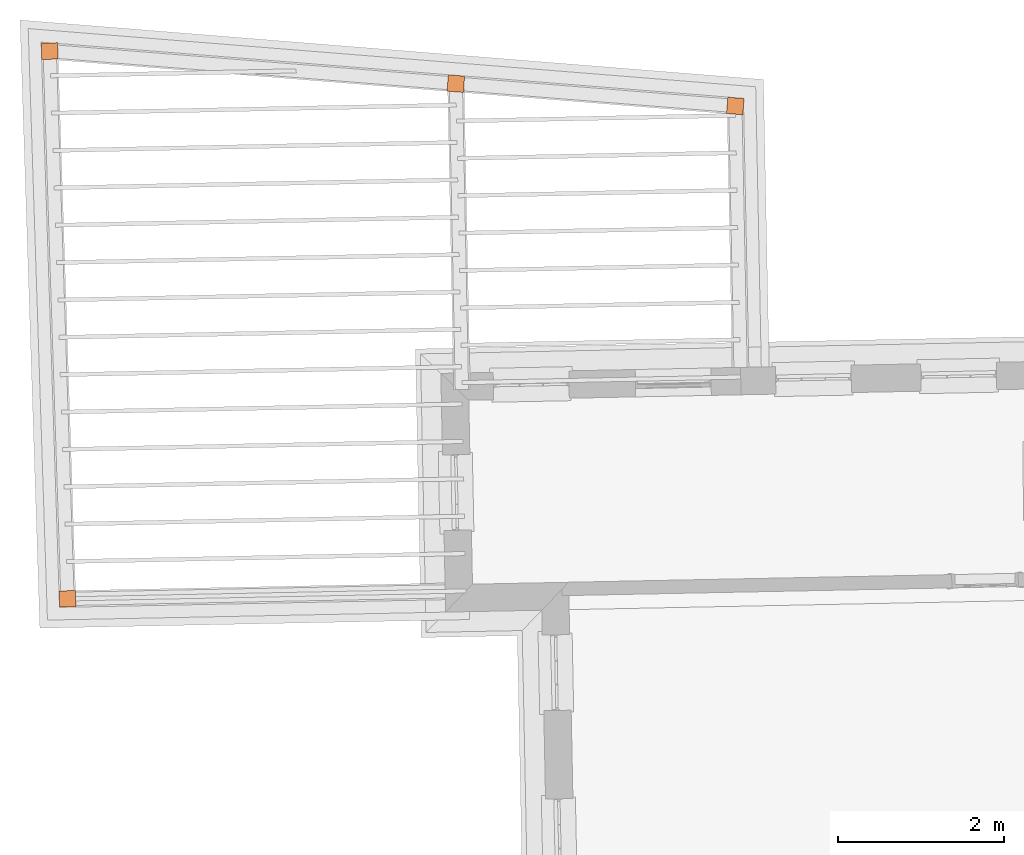
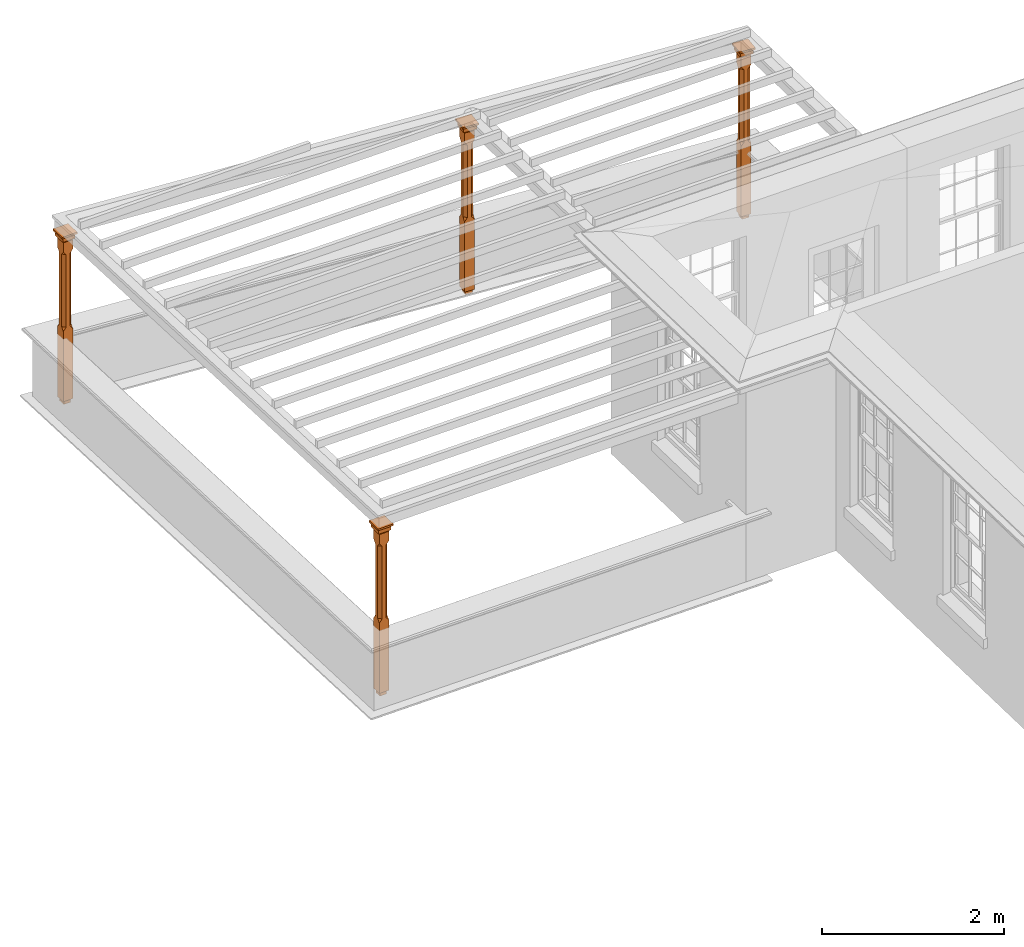
# One storey, part 11 of 11: 4 proxies.
"""IFC2X3 building model written with IfcOpenShell, lengths in metres."""

from ifc_helpers import new_model, si_unit, frame, origin, place, context, subcontext, project, spatial, faceted_brep, element, save


model = new_model("IFC2X3")

# Units and contexts
model_context = context("Model", 3, world=origin())
body_context = subcontext(model_context, "Body", "Model", "MODEL_VIEW")
ifc_project = project(units=[si_unit("PLANEANGLEUNIT", "RADIAN"), si_unit("MASSUNIT", "GRAM", prefix="KILO"), si_unit("FORCEUNIT", "NEWTON", prefix="KILO"), si_unit("LENGTHUNIT", "METRE")], contexts=[model_context])

# Site, building, storey
site_placement = place(None, origin())
site = spatial("IfcSite", under=ifc_project, at=site_placement, CompositionType="ELEMENT")
building_placement = place(None, origin())
building = spatial("IfcBuilding", under=site, at=building_placement, Name="Building plot-11", CompositionType="ELEMENT")
storey_placement = place(None, frame((0.0, 0.0, 5.3)))
storey = spatial("IfcBuildingStorey", under=building, at=storey_placement, Name="Floor 1", CompositionType="ELEMENT", Elevation=5.3)

# Proxies
proxy_1_placement = place(storey_placement, frame((62.0079202467552, 26.1266070742675, 0.0), z_axis=(0.0, 0.0, 1.0), x_axis=(-0.996812189422444, 0.0797838267998868, 0.0)))
element("IfcBuildingElementProxy", 1, at=proxy_1_placement, inside=storey, Name="pergola post", CompositionType="ELEMENT", context=body_context, shape_type="Brep", held_by="IfcProductRepresentation", body=[
    faceted_brep([(0.0246, -0.0615, 2.02), (0.0615, -0.0246, 2.02), (0.0615, -0.0615, 2.066667), (0.0615, -0.0246, 1.044444), (0.0246, -0.0615, 1.044444), (0.0615, 0.0246, 2.02), (0.0615, 0.0615, 2.066667), (-0.0246, -0.0615, 2.02), (-0.0615, -0.0615, 2.066667), (-0.0246, -0.0615, 1.044444), (0.0615, -0.0615, 0.997778), (0.0615, 0.0246, 1.044444), (0.0246, 0.0615, 2.02), (0.0615, 0.0615, 2.191111), (0.0615, -0.0615, 2.191111), (-0.0615, -0.0615, 2.191111), (-0.0615, -0.0246, 2.02), (-0.0615, -0.0246, 1.044444), (-0.0615, -0.0615, 0.997778), (0.0615, 0.0615, 0.997778), (0.0246, 0.0615, 1.044444), (-0.0246, 0.0615, 2.02), (-0.0615, 0.0615, 2.066667), (0.04305, 0.04305, 2.191111), (0.04305, -0.04305, 2.191111), (-0.0615, 0.0615, 2.191111), (-0.04305, -0.04305, 2.191111), (-0.0615, 0.0246, 2.02), (-0.0615, 0.0246, 1.044444), (0.0615, -0.0615, 0.053333), (-0.0615, -0.0615, 0.053333), (0.0615, 0.0615, 0.053333), (-0.0246, 0.0615, 1.044444), (-0.04305, 0.04305, 2.191111), (0.04305, 0.04305, 2.214444), (0.04305, -0.04305, 2.214444), (-0.04305, -0.04305, 2.214444), (-0.0615, 0.0615, 0.997778), (-0.0615, 0.0615, 0.053333), (-0.04305, -0.04305, 0.053333), (0.04305, -0.04305, 0.053333), (0.04305, 0.04305, 0.053333), (-0.04305, 0.04305, 2.214444), (0.07995, 0.07995, 2.214444), (0.07995, -0.07995, 2.214444), (-0.07995, -0.07995, 2.214444), (-0.04305, 0.04305, 0.053333), (-0.04305, -0.04305, 0.0), (0.04305, -0.04305, 0.0), (0.04305, 0.04305, 0.0), (-0.07995, 0.07995, 2.214444), (0.07995, 0.07995, 2.276667), (0.07995, -0.07995, 2.276667), (-0.07995, -0.07995, 2.276667), (-0.04305, 0.04305, 0.0), (-0.07995, 0.07995, 2.276667), (0.0984, 0.0984, 2.276667), (0.0984, -0.0984, 2.276667), (-0.0984, -0.0984, 2.276667), (-0.0984, 0.0984, 2.276667), (0.0984, 0.0984, 2.3), (0.0984, -0.0984, 2.3), (-0.0984, -0.0984, 2.3), (-0.0984, 0.0984, 2.3)], [[[0, 1, 2]], [[3, 1, 0, 4]], [[1, 5, 6, 2]], [[7, 0, 2, 8]], [[4, 0, 7, 9]], [[3, 4, 10]], [[1, 3, 11, 5]], [[5, 12, 6]], [[13, 14, 2, 6]], [[15, 8, 2, 14]], [[8, 16, 7]], [[9, 7, 16, 17]], [[9, 18, 10, 4]], [[3, 10, 19, 11]], [[20, 12, 5, 11]], [[21, 22, 6, 12]], [[14, 13, 23, 24]], [[13, 6, 22, 25]], [[25, 22, 8, 15]], [[26, 15, 14, 24]], [[16, 8, 22, 27]], [[27, 28, 17, 16]], [[17, 18, 9]], [[29, 10, 18, 30]], [[31, 19, 10, 29]], [[20, 11, 19]], [[12, 20, 32, 21]], [[21, 27, 22]], [[33, 23, 13, 25]], [[23, 34, 35, 24]], [[26, 33, 25, 15]], [[36, 26, 24, 35]], [[28, 27, 21, 32]], [[17, 28, 37, 18]], [[38, 30, 18, 37]], [[29, 30, 39, 40]], [[31, 38, 37, 19]], [[40, 41, 31, 29]], [[32, 20, 19, 37]], [[33, 42, 34, 23]], [[43, 44, 35, 34]], [[42, 33, 26, 36]], [[36, 35, 44, 45]], [[28, 32, 37]], [[46, 39, 30, 38]], [[39, 47, 48, 40]], [[46, 38, 31, 41]], [[49, 41, 40, 48]], [[43, 34, 42, 50]], [[43, 51, 52, 44]], [[45, 50, 42, 36]], [[53, 45, 44, 52]], [[46, 54, 47, 39]], [[54, 46, 41, 49]], [[50, 55, 51, 43]], [[56, 57, 52, 51]], [[55, 50, 45, 53]], [[53, 52, 57, 58]], [[56, 51, 55, 59]], [[56, 60, 61, 57]], [[58, 59, 55, 53]], [[62, 58, 57, 61]], [[59, 63, 60, 56]], [[63, 62, 61, 60]], [[58, 62, 63, 59]], [[47, 54, 49, 48]]]),
])
proxy_2_placement = place(storey_placement, frame((58.6436257730282, 26.39588175855, 0.0), z_axis=(0.0, 0.0, 1.0), x_axis=(-0.996812189422445, 0.0797838267998686, 0.0)))
element("IfcBuildingElementProxy", 2, at=proxy_2_placement, inside=storey, Name="pergola post", CompositionType="ELEMENT", context=body_context, shape_type="Brep", held_by="IfcProductRepresentation", body=[
    faceted_brep([(0.0246, -0.0615, 2.02), (0.0615, -0.0246, 2.02), (0.0615, -0.0615, 2.066667), (0.0615, -0.0246, 1.044444), (0.0246, -0.0615, 1.044444), (0.0615, 0.0246, 2.02), (0.0615, 0.0615, 2.066667), (-0.0246, -0.0615, 2.02), (-0.0615, -0.0615, 2.066667), (-0.0246, -0.0615, 1.044444), (0.0615, -0.0615, 0.997778), (0.0615, 0.0246, 1.044444), (0.0246, 0.0615, 2.02), (0.0615, 0.0615, 2.191111), (0.0615, -0.0615, 2.191111), (-0.0615, -0.0615, 2.191111), (-0.0615, -0.0246, 2.02), (-0.0615, -0.0246, 1.044444), (-0.0615, -0.0615, 0.997778), (0.0615, 0.0615, 0.997778), (0.0246, 0.0615, 1.044444), (-0.0246, 0.0615, 2.02), (-0.0615, 0.0615, 2.066667), (0.04305, 0.04305, 2.191111), (0.04305, -0.04305, 2.191111), (-0.0615, 0.0615, 2.191111), (-0.04305, -0.04305, 2.191111), (-0.0615, 0.0246, 2.02), (-0.0615, 0.0246, 1.044444), (0.0615, -0.0615, 0.053333), (-0.0615, -0.0615, 0.053333), (0.0615, 0.0615, 0.053333), (-0.0246, 0.0615, 1.044444), (-0.04305, 0.04305, 2.191111), (0.04305, 0.04305, 2.214444), (0.04305, -0.04305, 2.214444), (-0.04305, -0.04305, 2.214444), (-0.0615, 0.0615, 0.997778), (-0.0615, 0.0615, 0.053333), (-0.04305, -0.04305, 0.053333), (0.04305, -0.04305, 0.053333), (0.04305, 0.04305, 0.053333), (-0.04305, 0.04305, 2.214444), (0.07995, 0.07995, 2.214444), (0.07995, -0.07995, 2.214444), (-0.07995, -0.07995, 2.214444), (-0.04305, 0.04305, 0.053333), (-0.04305, -0.04305, 0.0), (0.04305, -0.04305, 0.0), (0.04305, 0.04305, 0.0), (-0.07995, 0.07995, 2.214444), (0.07995, 0.07995, 2.276667), (0.07995, -0.07995, 2.276667), (-0.07995, -0.07995, 2.276667), (-0.04305, 0.04305, 0.0), (-0.07995, 0.07995, 2.276667), (0.0984, 0.0984, 2.276667), (0.0984, -0.0984, 2.276667), (-0.0984, -0.0984, 2.276667), (-0.0984, 0.0984, 2.276667), (0.0984, 0.0984, 2.3), (0.0984, -0.0984, 2.3), (-0.0984, -0.0984, 2.3), (-0.0984, 0.0984, 2.3)], [[[0, 1, 2]], [[3, 1, 0, 4]], [[1, 5, 6, 2]], [[7, 0, 2, 8]], [[4, 0, 7, 9]], [[3, 4, 10]], [[1, 3, 11, 5]], [[5, 12, 6]], [[13, 14, 2, 6]], [[15, 8, 2, 14]], [[8, 16, 7]], [[9, 7, 16, 17]], [[9, 18, 10, 4]], [[3, 10, 19, 11]], [[20, 12, 5, 11]], [[21, 22, 6, 12]], [[14, 13, 23, 24]], [[13, 6, 22, 25]], [[25, 22, 8, 15]], [[26, 15, 14, 24]], [[16, 8, 22, 27]], [[27, 28, 17, 16]], [[17, 18, 9]], [[29, 10, 18, 30]], [[31, 19, 10, 29]], [[20, 11, 19]], [[12, 20, 32, 21]], [[21, 27, 22]], [[33, 23, 13, 25]], [[23, 34, 35, 24]], [[26, 33, 25, 15]], [[36, 26, 24, 35]], [[28, 27, 21, 32]], [[17, 28, 37, 18]], [[38, 30, 18, 37]], [[29, 30, 39, 40]], [[31, 38, 37, 19]], [[40, 41, 31, 29]], [[32, 20, 19, 37]], [[33, 42, 34, 23]], [[43, 44, 35, 34]], [[42, 33, 26, 36]], [[36, 35, 44, 45]], [[28, 32, 37]], [[46, 39, 30, 38]], [[39, 47, 48, 40]], [[46, 38, 31, 41]], [[49, 41, 40, 48]], [[43, 34, 42, 50]], [[43, 51, 52, 44]], [[45, 50, 42, 36]], [[53, 45, 44, 52]], [[46, 54, 47, 39]], [[54, 46, 41, 49]], [[50, 55, 51, 43]], [[56, 57, 52, 51]], [[55, 50, 45, 53]], [[53, 52, 57, 58]], [[56, 51, 55, 59]], [[56, 60, 61, 57]], [[58, 59, 55, 53]], [[62, 58, 57, 61]], [[59, 63, 60, 56]], [[63, 62, 61, 60]], [[58, 62, 63, 59]], [[47, 54, 49, 48]]]),
])
proxy_3_placement = place(storey_placement, frame((53.754980550035, 26.7871639157067, 0.0), z_axis=(0.0, 0.0, 1.0), x_axis=(0.0325614057467776, -0.999469736838387, 0.0)))
element("IfcBuildingElementProxy", 3, at=proxy_3_placement, inside=storey, Name="pergola post", CompositionType="ELEMENT", context=body_context, shape_type="Brep", held_by="IfcProductRepresentation", body=[
    faceted_brep([(0.0246, -0.0615, 2.02), (0.0615, -0.0246, 2.02), (0.0615, -0.0615, 2.066667), (0.0615, -0.0246, 1.044444), (0.0246, -0.0615, 1.044444), (0.0615, 0.0246, 2.02), (0.0615, 0.0615, 2.066667), (-0.0246, -0.0615, 2.02), (-0.0615, -0.0615, 2.066667), (-0.0246, -0.0615, 1.044444), (0.0615, -0.0615, 0.997778), (0.0615, 0.0246, 1.044444), (0.0246, 0.0615, 2.02), (0.0615, 0.0615, 2.191111), (0.0615, -0.0615, 2.191111), (-0.0615, -0.0615, 2.191111), (-0.0615, -0.0246, 2.02), (-0.0615, -0.0246, 1.044444), (-0.0615, -0.0615, 0.997778), (0.0615, 0.0615, 0.997778), (0.0246, 0.0615, 1.044444), (-0.0246, 0.0615, 2.02), (-0.0615, 0.0615, 2.066667), (0.04305, 0.04305, 2.191111), (0.04305, -0.04305, 2.191111), (-0.0615, 0.0615, 2.191111), (-0.04305, -0.04305, 2.191111), (-0.0615, 0.0246, 2.02), (-0.0615, 0.0246, 1.044444), (0.0615, -0.0615, 0.053333), (-0.0615, -0.0615, 0.053333), (0.0615, 0.0615, 0.053333), (-0.0246, 0.0615, 1.044444), (-0.04305, 0.04305, 2.191111), (0.04305, 0.04305, 2.214444), (0.04305, -0.04305, 2.214444), (-0.04305, -0.04305, 2.214444), (-0.0615, 0.0615, 0.997778), (-0.0615, 0.0615, 0.053333), (-0.04305, -0.04305, 0.053333), (0.04305, -0.04305, 0.053333), (0.04305, 0.04305, 0.053333), (-0.04305, 0.04305, 2.214444), (0.07995, 0.07995, 2.214444), (0.07995, -0.07995, 2.214444), (-0.07995, -0.07995, 2.214444), (-0.04305, 0.04305, 0.053333), (-0.04305, -0.04305, 0.0), (0.04305, -0.04305, 0.0), (0.04305, 0.04305, 0.0), (-0.07995, 0.07995, 2.214444), (0.07995, 0.07995, 2.276667), (0.07995, -0.07995, 2.276667), (-0.07995, -0.07995, 2.276667), (-0.04305, 0.04305, 0.0), (-0.07995, 0.07995, 2.276667), (0.0984, 0.0984, 2.276667), (0.0984, -0.0984, 2.276667), (-0.0984, -0.0984, 2.276667), (-0.0984, 0.0984, 2.276667), (0.0984, 0.0984, 2.3), (0.0984, -0.0984, 2.3), (-0.0984, -0.0984, 2.3), (-0.0984, 0.0984, 2.3)], [[[0, 1, 2]], [[3, 1, 0, 4]], [[1, 5, 6, 2]], [[7, 0, 2, 8]], [[4, 0, 7, 9]], [[3, 4, 10]], [[1, 3, 11, 5]], [[5, 12, 6]], [[13, 14, 2, 6]], [[15, 8, 2, 14]], [[8, 16, 7]], [[9, 7, 16, 17]], [[9, 18, 10, 4]], [[3, 10, 19, 11]], [[20, 12, 5, 11]], [[21, 22, 6, 12]], [[14, 13, 23, 24]], [[13, 6, 22, 25]], [[25, 22, 8, 15]], [[26, 15, 14, 24]], [[16, 8, 22, 27]], [[27, 28, 17, 16]], [[17, 18, 9]], [[29, 10, 18, 30]], [[31, 19, 10, 29]], [[20, 11, 19]], [[12, 20, 32, 21]], [[21, 27, 22]], [[33, 23, 13, 25]], [[23, 34, 35, 24]], [[26, 33, 25, 15]], [[36, 26, 24, 35]], [[28, 27, 21, 32]], [[17, 28, 37, 18]], [[38, 30, 18, 37]], [[29, 30, 39, 40]], [[31, 38, 37, 19]], [[40, 41, 31, 29]], [[32, 20, 19, 37]], [[33, 42, 34, 23]], [[43, 44, 35, 34]], [[42, 33, 26, 36]], [[36, 35, 44, 45]], [[28, 32, 37]], [[46, 39, 30, 38]], [[39, 47, 48, 40]], [[46, 38, 31, 41]], [[49, 41, 40, 48]], [[43, 34, 42, 50]], [[43, 51, 52, 44]], [[45, 50, 42, 36]], [[53, 45, 44, 52]], [[46, 54, 47, 39]], [[54, 46, 41, 49]], [[50, 55, 51, 43]], [[56, 57, 52, 51]], [[55, 50, 45, 53]], [[53, 52, 57, 58]], [[56, 51, 55, 59]], [[56, 60, 61, 57]], [[58, 59, 55, 53]], [[62, 58, 57, 61]], [[59, 63, 60, 56]], [[63, 62, 61, 60]], [[58, 62, 63, 59]], [[47, 54, 49, 48]]]),
])
proxy_4_placement = place(storey_placement, frame((53.9697987685744, 20.1933359335438, 0.0), z_axis=(0.0, 0.0, 1.0), x_axis=(0.999800128269413, 0.0199925864376253, 0.0)))
element("IfcBuildingElementProxy", 4, at=proxy_4_placement, inside=storey, Name="pergola post", CompositionType="ELEMENT", context=body_context, shape_type="Brep", held_by="IfcProductRepresentation", body=[
    faceted_brep([(0.0246, -0.0615, 2.02), (0.0615, -0.0246, 2.02), (0.0615, -0.0615, 2.066667), (0.0615, -0.0246, 1.044444), (0.0246, -0.0615, 1.044444), (0.0615, 0.0246, 2.02), (0.0615, 0.0615, 2.066667), (-0.0246, -0.0615, 2.02), (-0.0615, -0.0615, 2.066667), (-0.0246, -0.0615, 1.044444), (0.0615, -0.0615, 0.997778), (0.0615, 0.0246, 1.044444), (0.0246, 0.0615, 2.02), (0.0615, 0.0615, 2.191111), (0.0615, -0.0615, 2.191111), (-0.0615, -0.0615, 2.191111), (-0.0615, -0.0246, 2.02), (-0.0615, -0.0246, 1.044444), (-0.0615, -0.0615, 0.997778), (0.0615, 0.0615, 0.997778), (0.0246, 0.0615, 1.044444), (-0.0246, 0.0615, 2.02), (-0.0615, 0.0615, 2.066667), (0.04305, 0.04305, 2.191111), (0.04305, -0.04305, 2.191111), (-0.0615, 0.0615, 2.191111), (-0.04305, -0.04305, 2.191111), (-0.0615, 0.0246, 2.02), (-0.0615, 0.0246, 1.044444), (0.0615, -0.0615, 0.053333), (-0.0615, -0.0615, 0.053333), (0.0615, 0.0615, 0.053333), (-0.0246, 0.0615, 1.044444), (-0.04305, 0.04305, 2.191111), (0.04305, 0.04305, 2.214444), (0.04305, -0.04305, 2.214444), (-0.04305, -0.04305, 2.214444), (-0.0615, 0.0615, 0.997778), (-0.0615, 0.0615, 0.053333), (-0.04305, -0.04305, 0.053333), (0.04305, -0.04305, 0.053333), (0.04305, 0.04305, 0.053333), (-0.04305, 0.04305, 2.214444), (0.07995, 0.07995, 2.214444), (0.07995, -0.07995, 2.214444), (-0.07995, -0.07995, 2.214444), (-0.04305, 0.04305, 0.053333), (-0.04305, -0.04305, 0.0), (0.04305, -0.04305, 0.0), (0.04305, 0.04305, 0.0), (-0.07995, 0.07995, 2.214444), (0.07995, 0.07995, 2.276667), (0.07995, -0.07995, 2.276667), (-0.07995, -0.07995, 2.276667), (-0.04305, 0.04305, 0.0), (-0.07995, 0.07995, 2.276667), (0.0984, 0.0984, 2.276667), (0.0984, -0.0984, 2.276667), (-0.0984, -0.0984, 2.276667), (-0.0984, 0.0984, 2.276667), (0.0984, 0.0984, 2.3), (0.0984, -0.0984, 2.3), (-0.0984, -0.0984, 2.3), (-0.0984, 0.0984, 2.3)], [[[0, 1, 2]], [[3, 1, 0, 4]], [[1, 5, 6, 2]], [[7, 0, 2, 8]], [[4, 0, 7, 9]], [[3, 4, 10]], [[1, 3, 11, 5]], [[5, 12, 6]], [[13, 14, 2, 6]], [[15, 8, 2, 14]], [[8, 16, 7]], [[9, 7, 16, 17]], [[9, 18, 10, 4]], [[3, 10, 19, 11]], [[20, 12, 5, 11]], [[21, 22, 6, 12]], [[14, 13, 23, 24]], [[13, 6, 22, 25]], [[25, 22, 8, 15]], [[26, 15, 14, 24]], [[16, 8, 22, 27]], [[27, 28, 17, 16]], [[17, 18, 9]], [[29, 10, 18, 30]], [[31, 19, 10, 29]], [[20, 11, 19]], [[12, 20, 32, 21]], [[21, 27, 22]], [[33, 23, 13, 25]], [[23, 34, 35, 24]], [[26, 33, 25, 15]], [[36, 26, 24, 35]], [[28, 27, 21, 32]], [[17, 28, 37, 18]], [[38, 30, 18, 37]], [[29, 30, 39, 40]], [[31, 38, 37, 19]], [[40, 41, 31, 29]], [[32, 20, 19, 37]], [[33, 42, 34, 23]], [[43, 44, 35, 34]], [[42, 33, 26, 36]], [[36, 35, 44, 45]], [[28, 32, 37]], [[46, 39, 30, 38]], [[39, 47, 48, 40]], [[46, 38, 31, 41]], [[49, 41, 40, 48]], [[43, 34, 42, 50]], [[43, 51, 52, 44]], [[45, 50, 42, 36]], [[53, 45, 44, 52]], [[46, 54, 47, 39]], [[54, 46, 41, 49]], [[50, 55, 51, 43]], [[56, 57, 52, 51]], [[55, 50, 45, 53]], [[53, 52, 57, 58]], [[56, 51, 55, 59]], [[56, 60, 61, 57]], [[58, 59, 55, 53]], [[62, 58, 57, 61]], [[59, 63, 60, 56]], [[63, 62, 61, 60]], [[58, 62, 63, 59]], [[47, 54, 49, 48]]]),
])

save(model, "model.ifc")
